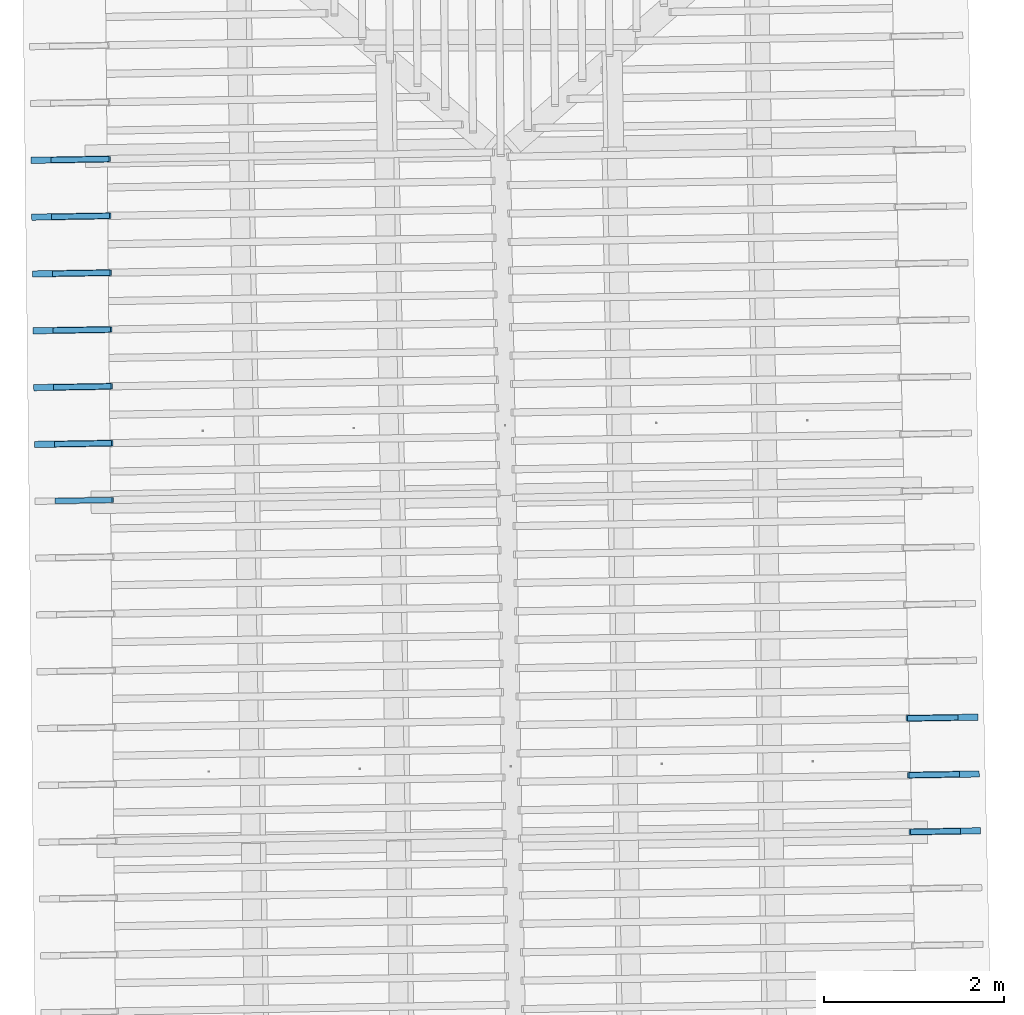
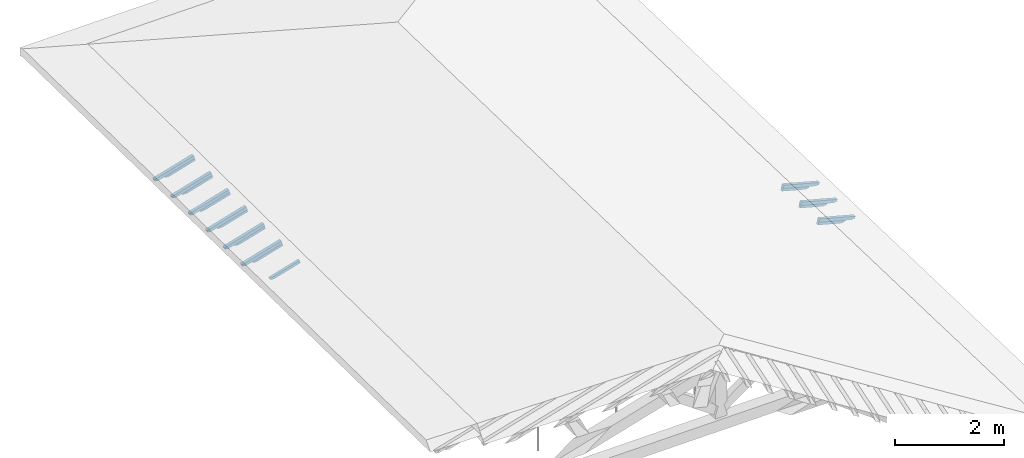
# One storey, part 13 of 19: 19 beams, 4 elements without a shape of their own.
"""IFC4 building model written with IfcOpenShell, lengths in metres."""

from ifc_helpers import new_model, entity, si_unit, converted_unit, derived_unit, direction, frame, origin, place, context, subcontext, project, spatial, line, arc, indexed_curve, outline, extrude, source, transform, mapped, material, type_object, type_shapes, element, aggregate, save


model = new_model("IFC4")

# Units and contexts
model_context = context("Model", 3, precision=1e-05, world=origin(), true_north=direction((6.123233995736766e-17, 1.0)))
body_context = subcontext(model_context, "Body", "Model", "MODEL_VIEW")
ifc_project = project(units=[si_unit("LENGTHUNIT", "METRE"), si_unit("AREAUNIT", "SQUARE_METRE"), si_unit("VOLUMEUNIT", "CUBIC_METRE"), converted_unit("PLANEANGLEUNIT", "DEGREE", entity("IfcPlaneAngleMeasure", 0.017453292519943278), si_unit("PLANEANGLEUNIT", "RADIAN"), dimensions=[0, 0, 0, 0, 0, 0, 0]), derived_unit("THERMALTRANSMITTANCEUNIT", [(si_unit("MASSUNIT", "GRAM", prefix="KILO"), 1), (si_unit("THERMODYNAMICTEMPERATUREUNIT", "KELVIN"), -1), (si_unit("TIMEUNIT", "SECOND"), -3)])], contexts=[model_context])

# Site, building, storey
site_placement = place(None, origin())
site = spatial("IfcSite", under=ifc_project, at=site_placement, CompositionType="ELEMENT")
building_placement = place(site_placement, origin())
building = spatial("IfcBuilding", under=site, at=building_placement, CompositionType="ELEMENT")
storey_placement = place(building_placement, frame((0.0, 0.0, 3.28)))
storey = spatial("IfcBuildingStorey", under=building, at=storey_placement, Name="Livello Copertura", CompositionType="ELEMENT", Elevation=3.28)

# Assembly, beams
assembly_1_placement = place(storey_placement, origin())
assembly_1 = element("IfcElementAssembly", 1, at=assembly_1_placement, inside=storey, Name="Sistema di travi strutturali:Sistema di travi strutturali", ObjectType="Sistema di travi strutturali:Sistema di travi strutturali", AssemblyPlace="NOTDEFINED", PredefinedType="BEAM_GRID")
ifc_material = material(Name="Legno - Legno da costruzione", Category="Legno")
beam_type_1 = type_object("IfcBeamType", Name="70x70:70x70", PredefinedType="JOIST", material=ifc_material)
shared_shape_1 = source(origin(), body_context, "Body", "SweptSolid", [
    extrude(outline(indexed_curve([(-0.04357142857143148, -0.5861428571428566), (0.02642857142856847, -0.5861428571428566), (0.02642857142856847, 0.18485714285714333), (0.012428571428584351, 0.18485714285713994), (0.02618186702937887, 0.20856674738504458), (0.018428571428570753, 0.23485714285714349), (0.00601411811084772, 0.25785271837212637), (0.0034285714285709253, 0.2838571428571433), (-0.04357142857143148, 0.2838571428571433)], segments=[line(1, 2, 3, 4), arc(4, 5, 6), arc(6, 7, 8), line(8, 9, 1)], self_intersect=False)), frame((-0.11614285714285659, -0.03500000000000078, -0.00857142857143325), z_axis=(0.0, 1.0, 0.0), x_axis=(0.0, 0.0, -1.0)), (0.0, 0.0, 1.0), 0.06999999999999999),
])
type_shapes(beam_type_1, [shared_shape_1])
beam_1_placement = place(assembly_1_placement, frame((-5.076874981741074, 9.108058186624556, 0.11271437186627264), z_axis=(-0.26888056974925345, -0.004594467440668786, 0.9631625667976584), x_axis=(0.9630219859926786, 0.01645553326303335, 0.26891982061526537)))
beam_1 = element("IfcBeam", 2, at=beam_1_placement, type_object=beam_type_1, material=ifc_material, Name="70x70:70x70", ObjectType="70x70:70x70", PredefinedType="JOIST", context=body_context, shape_type="MappedRepresentation", body=[
    mapped(shared_shape_1, transform((0.0, 0.0, 0.0), scale=1.0)),
])
beam_type_2 = type_object("IfcBeamType", Name="70x70:70x70", PredefinedType="JOIST", material=ifc_material)
shared_shape_2 = source(origin(), body_context, "Body", "SweptSolid", [
    extrude(outline(indexed_curve([(-0.04357142857143151, -0.5868571428571424), (0.026428571428568484, -0.5868571428571424), (0.026428571428568484, 0.18514285714285764), (0.012428571428584367, 0.18514285714285425), (0.026181867029378882, 0.20885246167075888), (0.01842857142857076, 0.23514285714285776), (0.006014118110847725, 0.2581384326578407), (0.003428571428570935, 0.2841428571428576), (-0.04357142857143151, 0.2841428571428576)], segments=[line(1, 2, 3, 4), arc(4, 5, 6), arc(6, 7, 8), line(8, 9, 1)], self_intersect=False)), frame((-0.11635714285714231, -0.03500000000000078, -0.008571428571433245), z_axis=(0.0, 1.0, 0.0), x_axis=(0.0, 0.0, -1.0)), (0.0, 0.0, 1.0), 0.06999999999999999),
])
type_shapes(beam_type_2, [shared_shape_2])
beam_2_placement = place(assembly_1_placement, frame((-5.083656356885718, 9.738034277266868, 0.11382635925158047), z_axis=(-0.2688805697492534, -0.004594467440668789, 0.9631625667976582), x_axis=(0.9630219859926785, 0.016455533263032826, 0.26891982061526537)))
beam_2 = element("IfcBeam", 3, at=beam_2_placement, type_object=beam_type_2, material=ifc_material, Name="70x70:70x70", ObjectType="70x70:70x70", PredefinedType="JOIST", context=body_context, shape_type="MappedRepresentation", body=[
    mapped(shared_shape_2, transform((0.0, 0.0, 0.0), scale=1.0)),
])
beam_type_3 = type_object("IfcBeamType", Name="70x70:70x70", PredefinedType="JOIST", material=ifc_material)
shared_shape_3 = source(origin(), body_context, "Body", "SweptSolid", [
    extrude(outline(indexed_curve([(-0.043571428571431474, -0.5875714285714281), (0.026428571428568512, -0.5875714285714281), (0.026428571428568512, 0.18542857142857191), (0.012428571428584416, 0.18542857142856853), (0.02618186702937893, 0.20913817595647316), (0.018428571428570677, 0.23542857142857204), (0.006014118110847642, 0.258424146943555), (0.003428571428570848, 0.28442857142857186), (-0.043571428571431474, 0.28442857142857186)], segments=[line(1, 2, 3, 4), arc(4, 5, 6), arc(6, 7, 8), line(8, 9, 1)], self_intersect=False)), frame((-0.11657142857142808, -0.03500000000000078, -0.008571428571433209), z_axis=(0.0, 1.0, 0.0), x_axis=(0.0, 0.0, -1.0)), (0.0, 0.0, 1.0), 0.06999999999999999),
])
type_shapes(beam_type_3, [shared_shape_3])
beam_3_placement = place(assembly_1_placement, frame((-5.090437732030361, 10.36801036790918, 0.1149383466368894), z_axis=(-0.2688805697492528, -0.004594467440668779, 0.9631625667976584), x_axis=(0.9630219859926787, 0.016455533263033464, 0.26891982061526476)))
beam_3 = element("IfcBeam", 4, at=beam_3_placement, type_object=beam_type_3, material=ifc_material, Name="70x70:70x70", ObjectType="70x70:70x70", PredefinedType="JOIST", context=body_context, shape_type="MappedRepresentation", body=[
    mapped(shared_shape_3, transform((0.0, 0.0, 0.0), scale=1.0)),
])
beam_type_4 = type_object("IfcBeamType", Name="70x70:70x70", PredefinedType="JOIST", material=ifc_material)
shared_shape_4 = source(origin(), body_context, "Body", "SweptSolid", [
    extrude(outline(indexed_curve([(-0.043571428571431474, -0.5889999999999995), (0.026428571428568515, -0.5889999999999995), (0.026428571428568515, 0.1860000000000005), (0.012428571428584417, 0.1859999999999971), (0.02618186702937893, 0.20970960452790174), (0.018428571428570663, 0.23600000000000063), (0.006014118110847628, 0.25899557551498353), (0.0034285714285708334, 0.2850000000000005), (-0.043571428571431474, 0.2850000000000005)], segments=[line(1, 2, 3, 4), arc(4, 5, 6), arc(6, 7, 8), line(8, 9, 1)], self_intersect=False)), frame((-0.11699999999999952, -0.03500000000000078, -0.008571428571433207), z_axis=(0.0, 1.0, 0.0), x_axis=(0.0, 0.0, -1.0)), (0.0, 0.0, 1.0), 0.06999999999999999),
])
type_shapes(beam_type_4, [shared_shape_4])
beam_4_placement = place(assembly_1_placement, frame((-5.097219107175006, 10.997986458551493, 0.11605033402219878), z_axis=(-0.2688805697492528, -0.004594467440668775, 0.9631625667976584), x_axis=(0.9630219859926787, 0.016455533263032934, 0.26891982061526476)))
beam_4 = element("IfcBeam", 5, at=beam_4_placement, type_object=beam_type_4, material=ifc_material, Name="70x70:70x70", ObjectType="70x70:70x70", PredefinedType="JOIST", context=body_context, shape_type="MappedRepresentation", body=[
    mapped(shared_shape_4, transform((0.0, 0.0, 0.0), scale=1.0)),
])
beam_type_5 = type_object("IfcBeamType", Name="70x70:70x70", PredefinedType="JOIST", material=ifc_material)
shared_shape_5 = source(origin(), body_context, "Body", "SweptSolid", [
    extrude(outline(indexed_curve([(-0.04357142857143147, -0.5897142857142853), (0.026428571428568526, -0.5897142857142853), (0.026428571428568526, 0.18628571428571478), (0.012428571428584428, 0.1862857142857114), (0.026181867029378945, 0.20999531881361602), (0.01842857142857064, 0.23628571428571493), (0.006014118110847603, 0.2592812898006978), (0.0034285714285708087, 0.28528571428571475), (-0.04357142857143147, 0.28528571428571475)], segments=[line(1, 2, 3, 4), arc(4, 5, 6), arc(6, 7, 8), line(8, 9, 1)], self_intersect=False)), frame((-0.11721428571428524, -0.03500000000000078, -0.008571428571433197), z_axis=(0.0, 1.0, 0.0), x_axis=(0.0, 0.0, -1.0)), (0.0, 0.0, 1.0), 0.06999999999999999),
])
type_shapes(beam_type_5, [shared_shape_5])
beam_5_placement = place(assembly_1_placement, frame((-5.104000482319649, 11.627962549193802, 0.11716232140750704), z_axis=(-0.2688805697492531, -0.004594467440668784, 0.9631625667976583), x_axis=(0.9630219859926786, 0.016455533263032427, 0.2689198206152651)))
beam_5 = element("IfcBeam", 6, at=beam_5_placement, type_object=beam_type_5, material=ifc_material, Name="70x70:70x70", ObjectType="70x70:70x70", PredefinedType="JOIST", context=body_context, shape_type="MappedRepresentation", body=[
    mapped(shared_shape_5, transform((0.0, 0.0, 0.0), scale=1.0)),
])
beam_type_6 = type_object("IfcBeamType", Name="70x70:70x70", PredefinedType="JOIST", material=ifc_material)
shared_shape_6 = source(origin(), body_context, "Body", "SweptSolid", [
    extrude(outline(indexed_curve([(-0.0435714285714315, -0.590428571428571), (0.02642857142856849, -0.590428571428571), (0.02642857142856849, 0.18657142857142905), (0.012428571428584377, 0.1865714285714257), (0.026181867029378893, 0.21028103309933033), (0.01842857142857074, 0.2365714285714292), (0.0060141181108477005, 0.25956700408641215), (0.0034285714285709106, 0.28557142857142903), (-0.0435714285714315, 0.28557142857142903)], segments=[line(1, 2, 3, 4), arc(4, 5, 6), arc(6, 7, 8), line(8, 9, 1)], self_intersect=False)), frame((-0.11742857142857087, -0.03500000000000078, -0.008571428571433235), z_axis=(0.0, 1.0, 0.0), x_axis=(0.0, 0.0, -1.0)), (0.0, 0.0, 1.0), 0.06999999999999999),
])
type_shapes(beam_type_6, [shared_shape_6])
beam_6_placement = place(assembly_1_placement, frame((-5.110781857464293, 12.257938639836116, 0.11827430879281575), z_axis=(-0.2688805697492526, -0.004594467440668772, 0.9631625667976585), x_axis=(0.9630219859926787, 0.016455533263034183, 0.26891982061526454)))
beam_6 = element("IfcBeam", 7, at=beam_6_placement, type_object=beam_type_6, material=ifc_material, Name="70x70:70x70", ObjectType="70x70:70x70", PredefinedType="JOIST", context=body_context, shape_type="MappedRepresentation", body=[
    mapped(shared_shape_6, transform((0.0, 0.0, 0.0), scale=1.0)),
])
aggregate(assembly_1, [beam_1, beam_2, beam_3, beam_4, beam_5, beam_6])

assembly_2_placement = place(storey_placement, origin())
assembly_2 = element("IfcElementAssembly", 8, at=assembly_2_placement, inside=storey, Name="Sistema di travi strutturali:Sistema di travi strutturali", ObjectType="Sistema di travi strutturali:Sistema di travi strutturali", AssemblyPlace="NOTDEFINED", PredefinedType="BEAM_GRID")
beam_type_7 = type_object("IfcBeamType", Name="60x60:60x60", PredefinedType="JOIST", material=ifc_material)
shared_shape_7 = source(origin(), body_context, "Body", "SweptSolid", [
    extrude(outline(indexed_curve([(-0.03585714285711783, -0.43342857142857166), (0.024142857142882147, -0.43342857142857166), (0.024142857142882147, 0.12557142857142845), (0.007142857142882212, 0.12557142857142845), (0.022800314198399146, 0.14316784462699617), (0.020142857142794186, 0.1665714285714296), (0.006097362558745389, 0.19472501701940936), (-0.003857142857205028, 0.22457142857142842), (-0.03585714285711783, 0.22457142857142848)], segments=[line(1, 2, 3, 4), arc(4, 5, 6), arc(6, 7, 8), line(8, 9, 1)], self_intersect=False)), frame((0.035571428571428455, -0.030000000000000786, -0.005857142857119568), z_axis=(0.0, 1.0, 0.0), x_axis=(0.0, 0.0, -1.0)), (0.0, 0.0, 1.0), 0.059999999999999984),
])
type_shapes(beam_type_7, [shared_shape_7])
beam_7_placement = place(assembly_2_placement, frame((-5.0526163695627275, 8.478380736365889, 0.04899681763911601), z_axis=(-0.2688805697492534, -0.004594467440668786, 0.9631625667976583), x_axis=(0.9630219859926785, 0.016455533263032736, 0.2689198206152653)))
beam_7 = element("IfcBeam", 9, at=beam_7_placement, type_object=beam_type_7, material=ifc_material, Name="60x60:60x60", ObjectType="60x60:60x60", PredefinedType="JOIST", context=body_context, shape_type="MappedRepresentation", body=[
    mapped(shared_shape_7, transform((0.0, 0.0, 0.0), scale=1.0)),
])
beam_type_8 = type_object("IfcBeamType", Name="60x60:60x60", PredefinedType="JOIST", material=ifc_material)
shared_shape_8 = source(origin(), body_context, "Body", "SweptSolid", [
    extrude(outline(indexed_curve([(-0.03585714285711777, -0.43485714285714316), (0.024142857142882217, -0.43485714285714316), (0.024142857142882217, 0.12614285714285703), (0.00714285714288228, 0.12614285714285703), (0.022800314198399212, 0.14373927319842478), (0.020142857142794016, 0.16714285714285818), (0.00609736255874522, 0.19529644559083795), (-0.003857142857205197, 0.225142857142857), (-0.03585714285711777, 0.22514285714285706)], segments=[line(1, 2, 3, 4), arc(4, 5, 6), arc(6, 7, 8), line(8, 9, 1)], self_intersect=False)), frame((0.03514285714285701, -0.030000000000000786, -0.0058571428571195005), z_axis=(0.0, 1.0, 0.0), x_axis=(0.0, 0.0, -1.0)), (0.0, 0.0, 1.0), 0.059999999999999984),
])
type_shapes(beam_type_8, [shared_shape_8])
beam_8_placement = place(assembly_2_placement, frame((-5.059397744707373, 9.1083568270082, 0.05010880502442516), z_axis=(-0.26888056974925345, -0.004594467440668786, 0.9631625667976584), x_axis=(0.9630219859926786, 0.01645553326303335, 0.26891982061526537)))
beam_8 = element("IfcBeam", 10, at=beam_8_placement, type_object=beam_type_8, material=ifc_material, Name="60x60:60x60", ObjectType="60x60:60x60", PredefinedType="JOIST", context=body_context, shape_type="MappedRepresentation", body=[
    mapped(shared_shape_8, transform((0.0, 0.0, 0.0), scale=1.0)),
])
beam_type_9 = type_object("IfcBeamType", Name="60x60:60x60", PredefinedType="JOIST", material=ifc_material)
shared_shape_9 = source(origin(), body_context, "Body", "SweptSolid", [
    extrude(outline(indexed_curve([(-0.03585714285711795, -0.4355714285714289), (0.024142857142882033, -0.4355714285714289), (0.024142857142882033, 0.12642857142857133), (0.007142857142882096, 0.12642857142857133), (0.022800314198399032, 0.14402498748413906), (0.020142857142794478, 0.16742857142857248), (0.006097362558745679, 0.19558215987655228), (-0.003857142857204738, 0.22542857142857128), (-0.03585714285711795, 0.22542857142857134)], segments=[line(1, 2, 3, 4), arc(4, 5, 6), arc(6, 7, 8), line(8, 9, 1)], self_intersect=False)), frame((0.03492857142857129, -0.030000000000000786, -0.005857142857119684), z_axis=(0.0, 1.0, 0.0), x_axis=(0.0, 0.0, -1.0)), (0.0, 0.0, 1.0), 0.059999999999999984),
])
type_shapes(beam_type_9, [shared_shape_9])
beam_9_placement = place(assembly_2_placement, frame((-5.066179119852016, 9.738332917650512, 0.05122079240973232), z_axis=(-0.2688805697492534, -0.004594467440668789, 0.9631625667976582), x_axis=(0.9630219859926785, 0.016455533263032826, 0.26891982061526537)))
beam_9 = element("IfcBeam", 11, at=beam_9_placement, type_object=beam_type_9, material=ifc_material, Name="60x60:60x60", ObjectType="60x60:60x60", PredefinedType="JOIST", context=body_context, shape_type="MappedRepresentation", body=[
    mapped(shared_shape_9, transform((0.0, 0.0, 0.0), scale=1.0)),
])
beam_type_10 = type_object("IfcBeamType", Name="60x60:60x60", PredefinedType="JOIST", material=ifc_material)
shared_shape_10 = source(origin(), body_context, "Body", "SweptSolid", [
    extrude(outline(indexed_curve([(-0.03585714285711775, -0.43628571428571444), (0.024142857142882224, -0.43628571428571444), (0.024142857142882224, 0.12671428571428556), (0.007142857142882289, 0.12671428571428556), (0.02280031419839922, 0.14431070176985328), (0.020142857142793992, 0.1677142857142867), (0.006097362558745195, 0.19586787416226648), (-0.0038571428572052213, 0.2257142857142855), (-0.03585714285711775, 0.22571428571428556)], segments=[line(1, 2, 3, 4), arc(4, 5, 6), arc(6, 7, 8), line(8, 9, 1)], self_intersect=False)), frame((0.03471428571428562, -0.030000000000000786, -0.005857142857119491), z_axis=(0.0, 1.0, 0.0), x_axis=(0.0, 0.0, -1.0)), (0.0, 0.0, 1.0), 0.059999999999999984),
])
type_shapes(beam_type_10, [shared_shape_10])
beam_10_placement = place(assembly_2_placement, frame((-5.072960494996659, 10.368309008292824, 0.05233277979504147), z_axis=(-0.2688805697492528, -0.004594467440668779, 0.9631625667976584), x_axis=(0.9630219859926787, 0.016455533263033464, 0.26891982061526476)))
beam_10 = element("IfcBeam", 12, at=beam_10_placement, type_object=beam_type_10, material=ifc_material, Name="60x60:60x60", ObjectType="60x60:60x60", PredefinedType="JOIST", context=body_context, shape_type="MappedRepresentation", body=[
    mapped(shared_shape_10, transform((0.0, 0.0, 0.0), scale=1.0)),
])
beam_type_11 = type_object("IfcBeamType", Name="60x60:60x60", PredefinedType="JOIST", material=ifc_material)
shared_shape_11 = source(origin(), body_context, "Body", "SweptSolid", [
    extrude(outline(indexed_curve([(-0.035857142857117906, -0.4377142857142859), (0.02414285714288207, -0.4377142857142859), (0.02414285714288207, 0.12728571428571414), (0.007142857142882135, 0.12728571428571414), (0.02280031419839907, 0.1448821303412819), (0.02014285714279438, 0.1682857142857153), (0.006097362558745583, 0.19643930273369506), (-0.003857142857204834, 0.22628571428571412), (-0.035857142857117906, 0.22628571428571417)], segments=[line(1, 2, 3, 4), arc(4, 5, 6), arc(6, 7, 8), line(8, 9, 1)], self_intersect=False)), frame((0.034285714285714176, -0.030000000000000786, -0.005857142857119645), z_axis=(0.0, 1.0, 0.0), x_axis=(0.0, 0.0, -1.0)), (0.0, 0.0, 1.0), 0.059999999999999984),
])
type_shapes(beam_type_11, [shared_shape_11])
beam_11_placement = place(assembly_2_placement, frame((-5.079741870141303, 10.998285098935137, 0.05344476718035063), z_axis=(-0.2688805697492528, -0.004594467440668775, 0.9631625667976584), x_axis=(0.9630219859926787, 0.016455533263032934, 0.26891982061526476)))
beam_11 = element("IfcBeam", 13, at=beam_11_placement, type_object=beam_type_11, material=ifc_material, Name="60x60:60x60", ObjectType="60x60:60x60", PredefinedType="JOIST", context=body_context, shape_type="MappedRepresentation", body=[
    mapped(shared_shape_11, transform((0.0, 0.0, 0.0), scale=1.0)),
])
beam_type_12 = type_object("IfcBeamType", Name="60x60:60x60", PredefinedType="JOIST", material=ifc_material)
shared_shape_12 = source(origin(), body_context, "Body", "SweptSolid", [
    extrude(outline(indexed_curve([(-0.03585714285711779, -0.43842857142857167), (0.024142857142882196, -0.43842857142857167), (0.024142857142882196, 0.12757142857142845), (0.00714285714288226, 0.12757142857142845), (0.02280031419839919, 0.1451678446269962), (0.020142857142794065, 0.16857142857142957), (0.006097362558745267, 0.19672501701940937), (-0.0038571428572051493, 0.2265714285714284), (-0.03585714285711779, 0.22657142857142848)], segments=[line(1, 2, 3, 4), arc(4, 5, 6), arc(6, 7, 8), line(8, 9, 1)], self_intersect=False)), frame((0.034071428571428454, -0.030000000000000786, -0.00585714285711952), z_axis=(0.0, 1.0, 0.0), x_axis=(0.0, 0.0, -1.0)), (0.0, 0.0, 1.0), 0.059999999999999984),
])
type_shapes(beam_type_12, [shared_shape_12])
beam_12_placement = place(assembly_2_placement, frame((-5.086523245285948, 11.628261189577445, 0.054556754565658894), z_axis=(-0.2688805697492531, -0.004594467440668784, 0.9631625667976583), x_axis=(0.9630219859926786, 0.016455533263032427, 0.2689198206152651)))
beam_12 = element("IfcBeam", 14, at=beam_12_placement, type_object=beam_type_12, material=ifc_material, Name="60x60:60x60", ObjectType="60x60:60x60", PredefinedType="JOIST", context=body_context, shape_type="MappedRepresentation", body=[
    mapped(shared_shape_12, transform((0.0, 0.0, 0.0), scale=1.0)),
])
beam_type_13 = type_object("IfcBeamType", Name="60x60:60x60", PredefinedType="JOIST", material=ifc_material)
shared_shape_13 = source(origin(), body_context, "Body", "SweptSolid", [
    extrude(outline(indexed_curve([(-0.0358571428571177, -0.4391428571428574), (0.024142857142882283, -0.4391428571428574), (0.024142857142882283, 0.12785714285714275), (0.007142857142882347, 0.12785714285714275), (0.02280031419839928, 0.14545355891271047), (0.020142857142793846, 0.1688571428571439), (0.0060973625587450505, 0.19701073130512367), (-0.003857142857205366, 0.22685714285714273), (-0.0358571428571177, 0.22685714285714279)], segments=[line(1, 2, 3, 4), arc(4, 5, 6), arc(6, 7, 8), line(8, 9, 1)], self_intersect=False)), frame((0.033857142857142725, -0.030000000000000786, -0.005857142857119433), z_axis=(0.0, 1.0, 0.0), x_axis=(0.0, 0.0, -1.0)), (0.0, 0.0, 1.0), 0.059999999999999984),
])
type_shapes(beam_type_13, [shared_shape_13])
beam_13_placement = place(assembly_2_placement, frame((-5.093304620430591, 12.25823728021976, 0.055668741950967826), z_axis=(-0.2688805697492526, -0.004594467440668772, 0.9631625667976585), x_axis=(0.9630219859926787, 0.016455533263034183, 0.26891982061526454)))
beam_13 = element("IfcBeam", 15, at=beam_13_placement, type_object=beam_type_13, material=ifc_material, Name="60x60:60x60", ObjectType="60x60:60x60", PredefinedType="JOIST", context=body_context, shape_type="MappedRepresentation", body=[
    mapped(shared_shape_13, transform((0.0, 0.0, 0.0), scale=1.0)),
])
aggregate(assembly_2, [beam_7, beam_8, beam_9, beam_10, beam_11, beam_12, beam_13])

assembly_3_placement = place(storey_placement, origin())
assembly_3 = element("IfcElementAssembly", 16, at=assembly_3_placement, inside=storey, Name="Sistema di travi strutturali:Sistema di travi strutturali", ObjectType="Sistema di travi strutturali:Sistema di travi strutturali", AssemblyPlace="NOTDEFINED", PredefinedType="BEAM_GRID")
beam_type_14 = type_object("IfcBeamType", Name="70x70:70x70", PredefinedType="JOIST", material=ifc_material)
shared_shape_14 = source(origin(), body_context, "Body", "SweptSolid", [
    extrude(outline(indexed_curve([(-0.043571428571431495, -0.5289999999999996), (0.026428571428568474, -0.5289999999999996), (0.026428571428568474, 0.1620000000000005), (0.01242857142858435, 0.16199999999999715), (0.026181867029378865, 0.18570960452790178), (0.018428571428570757, 0.21200000000000063), (0.006014118110847721, 0.23499557551498354), (0.003428571428570926, 0.26100000000000045), (-0.043571428571431495, 0.26100000000000045)], segments=[line(1, 2, 3, 4), arc(4, 5, 6), arc(6, 7, 8), line(8, 9, 1)], self_intersect=False)), frame((-0.09899999999999946, -0.03500000000000078, -0.008571428571433249), z_axis=(0.0, 1.0, 0.0), x_axis=(0.0, 0.0, -1.0)), (0.0, 0.0, 1.0), 0.06999999999999999),
])
type_shapes(beam_type_14, [shared_shape_14])
beam_14_placement = place(assembly_3_placement, frame((4.633123360392134, 6.072606695870942, 0.11258366832003608), z_axis=(0.2688805697492532, 0.0045944674406687685, 0.9631625667976583), x_axis=(-0.9630219859926786, -0.016455533263032406, 0.2689198206152651)))
beam_14 = element("IfcBeam", 17, at=beam_14_placement, type_object=beam_type_14, material=ifc_material, Name="70x70:70x70", ObjectType="70x70:70x70", PredefinedType="JOIST", context=body_context, shape_type="MappedRepresentation", body=[
    mapped(shared_shape_14, transform((0.0, 0.0, 0.0), scale=1.0)),
])
beam_type_15 = type_object("IfcBeamType", Name="70x70:70x70", PredefinedType="JOIST", material=ifc_material)
shared_shape_15 = source(origin(), body_context, "Body", "SweptSolid", [
    extrude(outline(indexed_curve([(-0.043571428571431474, -0.5282857142857138), (0.026428571428568505, -0.5282857142857138), (0.026428571428568505, 0.16171428571428625), (0.01242857142858439, 0.16171428571428278), (0.026181867029378907, 0.18542389024218742), (0.01842857142857069, 0.21171428571428638), (0.0060141181108476546, 0.2347098612292693), (0.0034285714285708555, 0.26071428571428623), (-0.043571428571431474, 0.26071428571428623)], segments=[line(1, 2, 3, 4), arc(4, 5, 6), arc(6, 7, 8), line(8, 9, 1)], self_intersect=False)), frame((-0.09878571428571371, -0.03500000000000078, -0.008571428571433214), z_axis=(0.0, 1.0, 0.0), x_axis=(0.0, 0.0, -1.0)), (0.0, 0.0, 1.0), 0.06999999999999999),
])
type_shapes(beam_type_15, [shared_shape_15])
beam_15_placement = place(assembly_3_placement, frame((4.647571366968558, 5.442761607957932, 0.1115547812711728), z_axis=(0.2688805697492537, 0.004594467440668777, 0.9631625667976582), x_axis=(-0.9630219859926785, -0.016455533263031934, 0.26891982061526565)))
beam_15 = element("IfcBeam", 18, at=beam_15_placement, type_object=beam_type_15, material=ifc_material, Name="70x70:70x70", ObjectType="70x70:70x70", PredefinedType="JOIST", context=body_context, shape_type="MappedRepresentation", body=[
    mapped(shared_shape_15, transform((0.0, 0.0, 0.0), scale=1.0)),
])
beam_type_16 = type_object("IfcBeamType", Name="70x70:70x70", PredefinedType="JOIST", material=ifc_material)
shared_shape_16 = source(origin(), body_context, "Body", "SweptSolid", [
    extrude(outline(indexed_curve([(-0.043571428571431495, -0.5275714285714281), (0.026428571428568495, -0.5275714285714281), (0.026428571428568495, 0.16142857142857195), (0.012428571428584398, 0.16142857142856856), (0.026181867029378917, 0.1851381759564732), (0.01842857142857071, 0.2114285714285721), (0.006014118110847676, 0.234424146943555), (0.003428571428570882, 0.2604285714285719), (-0.043571428571431495, 0.2604285714285719)], segments=[line(1, 2, 3, 4), arc(4, 5, 6), arc(6, 7, 8), line(8, 9, 1)], self_intersect=False)), frame((-0.09857142857142812, -0.03500000000000078, -0.008571428571433226), z_axis=(0.0, 1.0, 0.0), x_axis=(0.0, 0.0, -1.0)), (0.0, 0.0, 1.0), 0.06999999999999999),
])
type_shapes(beam_type_16, [shared_shape_16])
beam_16_placement = place(assembly_3_placement, frame((4.662019373544981, 4.81291652004492, 0.11052589422231018), z_axis=(0.2688805697492531, 0.004594467440668767, 0.9631625667976583), x_axis=(-0.9630219859926786, -0.016455533263032066, 0.26891982061526504)))
beam_16 = element("IfcBeam", 19, at=beam_16_placement, type_object=beam_type_16, material=ifc_material, Name="70x70:70x70", ObjectType="70x70:70x70", PredefinedType="JOIST", context=body_context, shape_type="MappedRepresentation", body=[
    mapped(shared_shape_16, transform((0.0, 0.0, 0.0), scale=1.0)),
])
aggregate(assembly_3, [beam_14, beam_15, beam_16])

assembly_4_placement = place(storey_placement, origin())
assembly_4 = element("IfcElementAssembly", 20, at=assembly_4_placement, inside=storey, Name="Sistema di travi strutturali:Sistema di travi strutturali", ObjectType="Sistema di travi strutturali:Sistema di travi strutturali", AssemblyPlace="NOTDEFINED", PredefinedType="BEAM_GRID")
beam_type_17 = type_object("IfcBeamType", Name="60x60:60x60", PredefinedType="JOIST", material=ifc_material)
shared_shape_17 = source(origin(), body_context, "Body", "SweptSolid", [
    extrude(outline(indexed_curve([(-0.035857142857117975, -0.377714285714286), (0.024142857142882005, -0.377714285714286), (0.024142857142882005, 0.10328571428571418), (0.007142857142882067, 0.10328571428571418), (0.022800314198399, 0.12088213034128191), (0.02014285714279455, 0.14428571428571532), (0.006097362558745752, 0.1724393027336951), (-0.003857142857204665, 0.20228571428571412), (-0.035857142857117975, 0.20228571428571418)], segments=[line(1, 2, 3, 4), arc(4, 5, 6), arc(6, 7, 8), line(8, 9, 1)], self_intersect=False)), frame((0.05228571428571412, -0.030000000000000786, -0.005857142857119713), z_axis=(0.0, 1.0, 0.0), x_axis=(0.0, 0.0, -1.0)), (0.0, 0.0, 1.0), 0.059999999999999984),
])
type_shapes(beam_type_17, [shared_shape_17])
beam_17_placement = place(assembly_4_placement, frame((4.615646123358433, 6.0723080554873, 0.0499781014781886), z_axis=(0.2688805697492532, 0.004594467440668769, 0.9631625667976583), x_axis=(-0.9630219859926786, -0.016455533263032406, 0.2689198206152651)))
beam_17 = element("IfcBeam", 21, at=beam_17_placement, type_object=beam_type_17, material=ifc_material, Name="60x60:60x60", ObjectType="60x60:60x60", PredefinedType="JOIST", context=body_context, shape_type="MappedRepresentation", body=[
    mapped(shared_shape_17, transform((0.0, 0.0, 0.0), scale=1.0)),
])
beam_type_18 = type_object("IfcBeamType", Name="60x60:60x60", PredefinedType="JOIST", material=ifc_material)
shared_shape_18 = source(origin(), body_context, "Body", "SweptSolid", [
    extrude(outline(indexed_curve([(-0.03585714285711758, -0.3770000000000003), (0.024142857142882397, -0.3770000000000003), (0.024142857142882397, 0.10299999999999987), (0.007142857142882463, 0.10299999999999987), (0.022800314198399393, 0.12059641605556762), (0.020142857142793555, 0.14400000000000102), (0.00609736255874476, 0.1721535884479808), (-0.0038571428572056568, 0.20199999999999982), (-0.03585714285711758, 0.2019999999999999)], segments=[line(1, 2, 3, 4), arc(4, 5, 6), arc(6, 7, 8), line(8, 9, 1)], self_intersect=False)), frame((0.05249999999999985, -0.030000000000000786, -0.0058571428571193174), z_axis=(0.0, 1.0, 0.0), x_axis=(0.0, 0.0, -1.0)), (0.0, 0.0, 1.0), 0.059999999999999984),
])
type_shapes(beam_type_18, [shared_shape_18])
beam_18_placement = place(assembly_4_placement, frame((4.630094129934857, 5.4424629675742855, 0.04894921442932487), z_axis=(0.2688805697492537, 0.004594467440668778, 0.9631625667976582), x_axis=(-0.9630219859926785, -0.016455533263033194, 0.26891982061526565)))
beam_18 = element("IfcBeam", 22, at=beam_18_placement, type_object=beam_type_18, material=ifc_material, Name="60x60:60x60", ObjectType="60x60:60x60", PredefinedType="JOIST", context=body_context, shape_type="MappedRepresentation", body=[
    mapped(shared_shape_18, transform((0.0, 0.0, 0.0), scale=1.0)),
])
beam_type_19 = type_object("IfcBeamType", Name="60x60:60x60", PredefinedType="JOIST", material=ifc_material)
shared_shape_19 = source(origin(), body_context, "Body", "SweptSolid", [
    extrude(outline(indexed_curve([(-0.03585714285711814, -0.3762857142857145), (0.02414285714288184, -0.3762857142857145), (0.02414285714288184, 0.10271428571428558), (0.007142857142881902, 0.10271428571428558), (0.022800314198398838, 0.12031070176985331), (0.02014285714279496, 0.1437142857142867), (0.0060973625587461625, 0.1718678741622665), (-0.0038571428572042547, 0.20171428571428554), (-0.03585714285711814, 0.20171428571428562)], segments=[line(1, 2, 3, 4), arc(4, 5, 6), arc(6, 7, 8), line(8, 9, 1)], self_intersect=False)), frame((0.052714285714285575, -0.030000000000000786, -0.005857142857119878), z_axis=(0.0, 1.0, 0.0), x_axis=(0.0, 0.0, -1.0)), (0.0, 0.0, 1.0), 0.059999999999999984),
])
type_shapes(beam_type_19, [shared_shape_19])
beam_19_placement = place(assembly_4_placement, frame((4.64454213651128, 4.812617879661276, 0.047920327380461814), z_axis=(0.26888056974925345, 0.00459446744066877, 0.9631625667976584), x_axis=(-0.9630219859926786, -0.016455533263032077, 0.26891982061526537)))
beam_19 = element("IfcBeam", 23, at=beam_19_placement, type_object=beam_type_19, material=ifc_material, Name="60x60:60x60", ObjectType="60x60:60x60", PredefinedType="JOIST", context=body_context, shape_type="MappedRepresentation", body=[
    mapped(shared_shape_19, transform((0.0, 0.0, 0.0), scale=1.0)),
])
aggregate(assembly_4, [beam_17, beam_18, beam_19])

save(model, "model.ifc")
